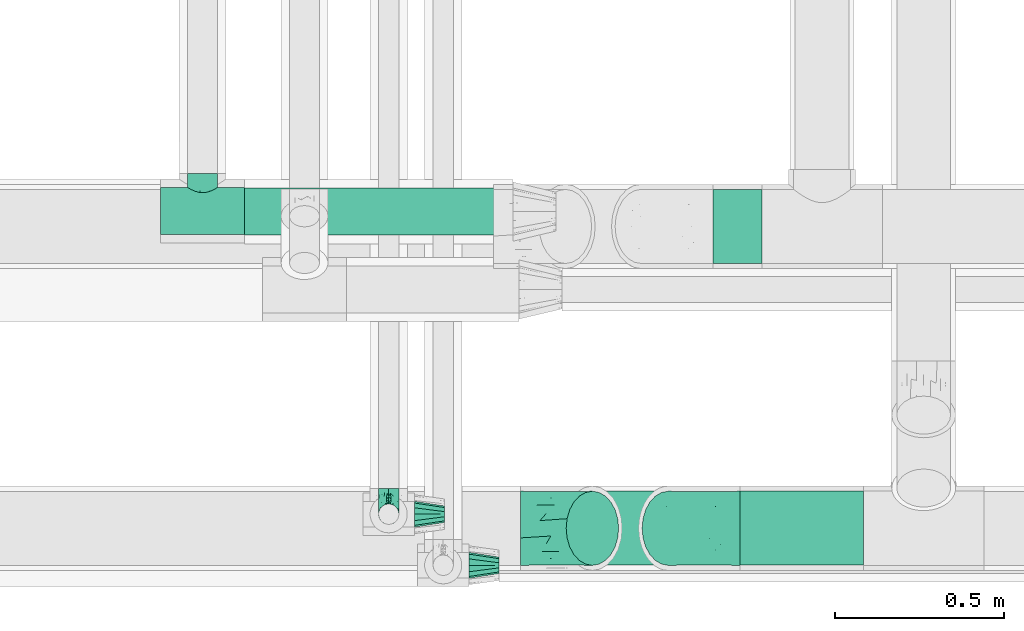
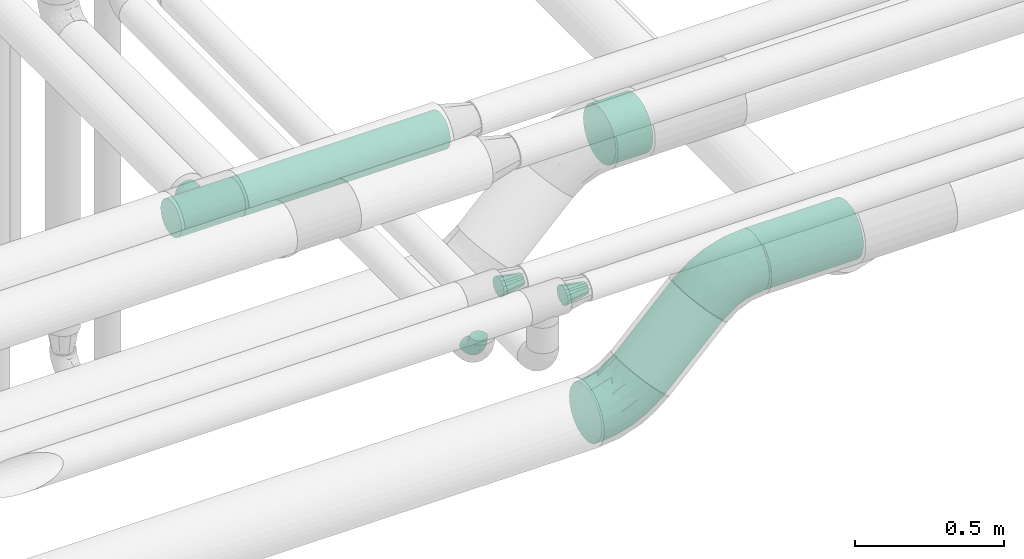
# One storey, part 604 of 827: 6 flow fittings, 4 flow segments.
"""IFC2X3 building model written with IfcOpenShell, lengths in millimetres."""

from ifc_helpers import new_model, entity, si_unit, converted_unit, derived_unit, direction, frame, origin, origin_2d_with_axis, place, context, subcontext, project, spatial, circle, extrude, faceted_brep, source, transform, mapped, material, type_object, type_shapes, element, save


model = new_model("IFC2X3")

# Units and contexts
model_context = context("Model", 3, precision=0.01, world=origin(), true_north=direction((6.12303176911189e-17, 1.0)))
body_context = subcontext(model_context, "Body", "Model", "MODEL_VIEW")
ifc_project = project(units=[si_unit("LENGTHUNIT", "METRE", prefix="MILLI"), si_unit("AREAUNIT", "SQUARE_METRE"), si_unit("VOLUMEUNIT", "CUBIC_METRE"), converted_unit("PLANEANGLEUNIT", "DEGREE", entity("IfcRatioMeasure", 0.0174532925199433), si_unit("PLANEANGLEUNIT", "RADIAN"), dimensions=[0, 0, 0, 0, 0, 0, 0]), si_unit("MASSUNIT", "GRAM", prefix="KILO"), derived_unit("MASSDENSITYUNIT", [(si_unit("MASSUNIT", "GRAM", prefix="KILO"), 1), (si_unit("LENGTHUNIT", "METRE"), -3)]), derived_unit("MOMENTOFINERTIAUNIT", [(si_unit("LENGTHUNIT", "METRE"), 4)]), si_unit("TIMEUNIT", "SECOND"), si_unit("FREQUENCYUNIT", "HERTZ"), si_unit("THERMODYNAMICTEMPERATUREUNIT", "DEGREE_CELSIUS"), derived_unit("THERMALTRANSMITTANCEUNIT", [(si_unit("MASSUNIT", "GRAM", prefix="KILO"), 1), (si_unit("THERMODYNAMICTEMPERATUREUNIT", "KELVIN"), -1), (si_unit("TIMEUNIT", "SECOND"), -3)]), derived_unit("VOLUMETRICFLOWRATEUNIT", [(si_unit("LENGTHUNIT", "METRE"), 3), (si_unit("TIMEUNIT", "SECOND"), -1)]), derived_unit("MASSFLOWRATEUNIT", [(si_unit("MASSUNIT", "GRAM", prefix="KILO"), 1), (si_unit("TIMEUNIT", "SECOND"), -1)]), derived_unit("ROTATIONALFREQUENCYUNIT", [(si_unit("TIMEUNIT", "SECOND"), -1)]), si_unit("ELECTRICCURRENTUNIT", "AMPERE"), si_unit("ELECTRICVOLTAGEUNIT", "VOLT"), si_unit("POWERUNIT", "WATT"), si_unit("FORCEUNIT", "NEWTON", prefix="KILO"), si_unit("ILLUMINANCEUNIT", "LUX"), si_unit("LUMINOUSFLUXUNIT", "LUMEN"), si_unit("LUMINOUSINTENSITYUNIT", "CANDELA"), derived_unit("USERDEFINED", [(si_unit("MASSUNIT", "GRAM", prefix="KILO"), -1), (si_unit("LENGTHUNIT", "METRE"), -2), (si_unit("TIMEUNIT", "SECOND"), 3), (si_unit("LUMINOUSFLUXUNIT", "LUMEN"), 1)]), derived_unit("LINEARVELOCITYUNIT", [(si_unit("LENGTHUNIT", "METRE"), 1), (si_unit("TIMEUNIT", "SECOND"), -1)]), si_unit("PRESSUREUNIT", "PASCAL"), derived_unit("USERDEFINED", [(si_unit("LENGTHUNIT", "METRE"), -2), (si_unit("MASSUNIT", "GRAM", prefix="KILO"), 1), (si_unit("TIMEUNIT", "SECOND"), -2)]), derived_unit("LINEARFORCEUNIT", [(si_unit("MASSUNIT", "GRAM", prefix="KILO"), 1), (si_unit("LENGTHUNIT", "METRE"), 1), (si_unit("TIMEUNIT", "SECOND"), -2), (si_unit("LENGTHUNIT", "METRE"), -1)]), derived_unit("PLANARFORCEUNIT", [(si_unit("MASSUNIT", "GRAM", prefix="KILO"), 1), (si_unit("LENGTHUNIT", "METRE"), 1), (si_unit("TIMEUNIT", "SECOND"), -2), (si_unit("LENGTHUNIT", "METRE"), -2)])], contexts=[model_context])

# Site, building, storey
site_placement = place(None, origin())
site = spatial("IfcSite", under=ifc_project, at=site_placement, CompositionType="ELEMENT")
building_placement = place(site_placement, origin())
building = spatial("IfcBuilding", under=site, at=building_placement, CompositionType="ELEMENT")
storey_placement = place(building_placement, frame((0.0, 0.0, 28200.0)))
storey = spatial("IfcBuildingStorey", under=building, at=storey_placement, Name="08", CompositionType="ELEMENT", Elevation=28200.0)

# Flow segments
pipe_segment_type_1 = type_object("IfcPipeSegmentType", PredefinedType="NOTDEFINED")
flow_segment_1_placement = place(storey_placement, frame((37506.49, 6263.9, 2788.9)))
element("IfcFlowSegment", 1, at=flow_segment_1_placement, inside=storey, type_object=pipe_segment_type_1, context=body_context, shape_type="SweptSolid", body=[
    extrude(circle(Radius=109.5, at=origin_2d_with_axis()), frame((0.0, 111.1, 111.1), z_axis=(1.0, 0.0, 0.0), x_axis=(0.0, 1.0, 0.0)), (0.0, 0.0, 1.0), 363.810001287764),
])
flow_segment_2_placement = place(storey_placement, frame((36991.07, 6263.9, 2508.84)))
element("IfcFlowSegment", 2, at=flow_segment_2_placement, inside=storey, type_object=pipe_segment_type_1, context=body_context, shape_type="SweptSolid", body=[
    extrude(circle(Radius=109.5, at=origin_2d_with_axis()), frame((79.02, 111.1, 79.02), z_axis=(0.70710679250001, 0.0, 0.707106769873085), x_axis=(0.0, 1.0, 0.0)), (0.0, 0.0, 1.0), 317.157302199655),
])
flow_segment_3_placement = place(storey_placement, frame((37426.66, 7155.11, 2788.78)))
element("IfcFlowSegment", 3, at=flow_segment_3_placement, inside=storey, type_object=pipe_segment_type_1, context=body_context, shape_type="SweptSolid", body=[
    extrude(circle(Radius=109.5, at=origin_2d_with_axis()), frame((0.0, 111.1, 111.1), z_axis=(1.0, 0.0, 0.0), x_axis=(0.0, 1.0, 0.0)), (0.0, 0.0, 1.0), 143.641200592173),
])
pipe_segment_type_2 = type_object("IfcPipeSegmentType", PredefinedType="NOTDEFINED")
flow_segment_4_placement = place(storey_placement, frame((36043.07, 7238.4, 3028.4)))
element("IfcFlowSegment", 4, at=flow_segment_4_placement, inside=storey, type_object=pipe_segment_type_2, context=body_context, shape_type="SweptSolid", body=[
    extrude(circle(Radius=70.0, at=origin_2d_with_axis()), frame((0.0, 71.6, 71.6), z_axis=(1.0, 0.0, 0.0), x_axis=(0.0, 1.0, 0.0)), (0.0, 0.0, 1.0), 791.966250687601),
])

# Flow fittings
ifc_material = material()
pipe_fitting_type_1 = type_object("IfcPipeFittingType", Name="ADSK_1", PredefinedType="NOTDEFINED", material=ifc_material)
shared_shape_1 = source(origin(), body_context, "Body", "Brep", [
    faceted_brep([(-76.0, 15.07, -26.11), (-76.0, 7.8, -29.12), (-76.0, 0.0, -30.15), (-76.0, -7.8, -29.12), (-76.0, -15.08, -26.11), (-76.0, -21.32, -21.32), (-76.0, -26.11, -15.08), (-76.0, -29.12, -7.8), (-76.0, -30.15, 0.0), (-76.0, -29.12, 7.8), (-76.0, -26.11, 15.07), (-76.0, -21.32, 21.32), (-76.0, -15.08, 26.11), (-76.0, -7.8, 29.12), (-76.0, 0.0, 30.15), (-76.0, 7.8, 29.12), (-76.0, 15.07, 26.11), (-76.0, 21.32, 21.32), (-76.0, 26.11, 15.07), (-76.0, 29.12, 7.8), (-76.0, 30.15, 0.0), (-76.0, 29.12, -7.8), (-76.0, 26.11, -15.08), (-76.0, 21.32, -21.32), (0.0, 76.0, -30.15), (-7.8, 76.0, -29.12), (-15.07, 76.0, -26.11), (-21.32, 76.0, -21.32), (-26.11, 76.0, -15.08), (-29.12, 76.0, -7.8), (-30.15, 76.0, 0.0), (-29.12, 76.0, 7.8), (-26.11, 76.0, 15.07), (-21.32, 76.0, 21.32), (-15.07, 76.0, 26.11), (-7.8, 76.0, 29.12), (0.0, 76.0, 30.15), (7.8, 76.0, 29.12), (15.08, 76.0, 26.11), (21.32, 76.0, 21.32), (26.11, 76.0, 15.07), (29.12, 76.0, 7.8), (30.15, 76.0, 0.0), (29.12, 76.0, -7.8), (26.11, 76.0, -15.08), (21.32, 76.0, -21.32), (15.08, 76.0, -26.11), (7.8, 76.0, -29.12), (10.79, 31.43, 21.07), (4.32, 31.7, 25.72), (1.65, 15.19, 19.92), (-61.17, -27.8, 0.0), (-51.1, -25.49, 9.84), (-56.14, -10.61, 27.27), (-31.7, -4.32, 25.72), (-39.75, 1.72, 29.41), (-43.2, -24.95, 0.0), (-1.86, 1.86, 0.0), (4.49, 7.65, 5.78), (-7.82, -4.61, 5.83), (-56.21, -22.79, 17.21), (-58.98, -3.38, 29.7), (-53.96, 5.6, 30.07), (-10.86, 10.86, 25.48), (-17.2, -2.6, 20.44), (-49.15, -16.01, 22.7), (-22.18, -14.24, 7.99), (-28.4, -17.42, 0.0), (-13.61, -9.88, 0.0), (-39.0, 23.48, 27.76), (-58.76, 12.54, 28.36), (-41.61, 15.41, 29.48), (16.01, 49.15, 22.7), (-58.55, 25.93, 19.53), (-51.53, 33.5, 13.51), (-64.92, 28.76, 12.4), (-7.48, 23.14, 28.25), (-1.72, 39.75, 29.41), (-12.04, 27.88, 29.88), (-63.91, 18.81, 24.52), (-11.63, 65.16, 28.18), (-4.97, 57.02, 30.05), (9.88, 13.61, 0.0), (-62.5, 31.74, 5.02), (-45.17, 30.98, 21.2), (-21.78, 9.76, 28.58), (10.61, 56.14, 27.27), (-32.09, 54.42, 13.26), (22.79, 56.21, 17.21), (15.38, 31.17, 15.63), (25.49, 51.1, 9.84), (21.84, 36.35, 5.92), (24.95, 43.2, 0.0), (3.38, 58.98, 29.7), (-31.17, -15.38, 15.63), (-39.39, 41.78, 15.45), (-34.56, 41.13, 20.79), (-39.81, -23.25, 5.49), (27.8, 61.17, 0.0), (-31.74, 62.5, 5.02), (-53.07, 36.29, 0.0), (-42.95, 42.95, 7.29), (-36.29, 53.07, 0.0), (-19.83, 58.51, 24.79), (-25.48, 60.2, 19.41), (-14.53, 50.96, 28.57), (-13.31, 37.09, 30.07), (-26.16, 40.06, 26.4), (-32.43, -10.35, 21.9), (17.42, 28.4, 0.0), (14.24, 22.18, 7.99), (-38.67, 9.72, 30.15), (-24.66, 17.36, 30.09), (-37.08, 31.49, 24.99), (-49.27, 22.83, 25.24), (-20.8, 38.81, 28.63), (-27.58, 27.58, 29.2), (-36.07, -20.23, 10.71), (-15.19, -6.16, 14.9), (6.6, 15.4, 14.49), (-2.51, 2.51, 11.35), (-65.16, 11.63, -28.18), (-49.15, -16.01, -22.7), (-57.02, 4.97, -30.05), (-25.93, 58.55, -19.53), (-33.5, 51.53, -13.51), (-28.76, 64.92, -12.4), (-60.2, 25.48, -19.41), (-58.51, 19.83, -24.79), (4.61, 7.82, -5.83), (-7.65, -4.49, -5.78), (-2.51, 2.51, -11.35), (-62.5, 31.74, -5.02), (-50.96, 14.53, -28.57), (-37.09, 13.31, -30.07), (-42.95, 42.95, -7.29), (25.49, 51.1, -9.84), (22.79, 56.21, -17.21), (-40.06, 26.16, -26.4), (3.38, 58.98, -29.7), (-5.6, 53.96, -30.07), (-27.88, 12.04, -29.88), (-9.76, 21.78, -28.58), (-23.14, 7.48, -28.25), (-51.1, -25.49, -9.84), (15.38, 31.17, -15.63), (16.01, 49.15, -22.7), (-23.48, 39.0, -27.76), (-12.54, 58.76, -28.36), (-15.41, 41.61, -29.48), (-56.21, -22.79, -17.21), (-9.72, 38.67, -30.15), (-17.36, 24.66, -30.09), (-22.18, -14.24, -7.99), (-41.13, 34.56, -20.79), (-31.74, 62.5, -5.02), (-58.98, -3.38, -29.7), (-31.17, -15.38, -15.63), (-56.14, -10.61, -27.27), (14.24, 22.18, -7.99), (23.25, 39.81, -5.49), (-31.49, 37.08, -24.99), (-15.19, -6.16, -14.9), (1.65, 15.19, -19.92), (-18.81, 63.91, -24.52), (-32.59, -11.62, -20.84), (-31.7, -4.32, -25.72), (-17.2, -2.6, -20.44), (-39.75, 1.72, -29.41), (-54.42, 32.09, -13.26), (-30.98, 45.17, -21.2), (10.61, 56.14, -27.27), (10.23, 31.31, -21.52), (4.32, 31.7, -25.72), (-41.78, 39.39, -15.45), (-1.72, 39.75, -29.41), (-36.35, -21.84, -5.92), (-22.83, 49.27, -25.24), (-38.81, 20.8, -28.63), (-27.58, 27.58, -29.2), (-10.86, 10.86, -25.48), (20.23, 36.07, -10.71), (6.6, 15.4, -14.49)], [[[0, 1, 2, 3, 4, 5, 6, 7, 8, 9, 10, 11, 12, 13, 14, 15, 16, 17, 18, 19, 20, 21, 22, 23]], [[24, 25, 26, 27, 28, 29, 30, 31, 32, 33, 34, 35, 36, 37, 38, 39, 40, 41, 42, 43, 44, 45, 46, 47]], [[48, 49, 50]], [[51, 52, 9]], [[53, 54, 55]], [[9, 52, 10]], [[56, 52, 51]], [[57, 58, 59]], [[11, 10, 60]], [[14, 61, 62]], [[63, 54, 64]], [[65, 12, 11]], [[65, 53, 12]], [[66, 67, 68]], [[69, 70, 71]], [[72, 39, 38]], [[73, 74, 75]], [[15, 70, 16]], [[76, 77, 78]], [[16, 79, 17]], [[13, 61, 14]], [[35, 80, 81]], [[14, 62, 15]], [[17, 73, 18]], [[57, 82, 58]], [[20, 19, 83]], [[75, 19, 18]], [[70, 15, 62]], [[73, 84, 74]], [[78, 85, 76]], [[38, 86, 72]], [[32, 31, 87]], [[88, 89, 90]], [[91, 92, 90]], [[72, 86, 49]], [[36, 93, 37]], [[75, 83, 19]], [[36, 35, 81]], [[60, 94, 65]], [[40, 90, 41]], [[95, 96, 87]], [[88, 90, 40]], [[66, 97, 67]], [[90, 98, 41]], [[40, 39, 88]], [[99, 31, 30]], [[20, 83, 100]], [[101, 102, 100]], [[52, 60, 10]], [[102, 99, 30]], [[96, 103, 104]], [[83, 101, 100]], [[12, 53, 13]], [[104, 103, 33]], [[105, 106, 81]], [[107, 105, 103]], [[64, 54, 108]], [[80, 103, 105]], [[80, 35, 34]], [[34, 33, 103]], [[86, 38, 37]], [[109, 110, 82]], [[71, 111, 112]], [[69, 107, 113]], [[79, 73, 17]], [[114, 113, 84]], [[33, 32, 104]], [[115, 107, 116]], [[105, 115, 106]], [[93, 81, 77]], [[54, 53, 65]], [[61, 53, 55]], [[108, 94, 64]], [[54, 63, 85]], [[93, 86, 37]], [[77, 76, 49]], [[77, 49, 86]], [[49, 63, 50]], [[60, 52, 117]], [[65, 11, 60]], [[39, 72, 88]], [[89, 88, 72]], [[71, 70, 62]], [[79, 70, 114]], [[103, 96, 107]], [[69, 113, 114]], [[112, 106, 116]], [[77, 81, 106]], [[112, 116, 71]], [[112, 55, 85]], [[64, 50, 63]], [[57, 59, 68]], [[32, 87, 104]], [[96, 104, 87]], [[94, 118, 64]], [[50, 119, 89]], [[50, 64, 118]], [[50, 89, 48]], [[81, 93, 36]], [[86, 93, 77]], [[53, 61, 13]], [[62, 61, 55]], [[71, 62, 111]], [[69, 71, 116]], [[95, 101, 74]], [[99, 101, 87]], [[118, 66, 59]], [[117, 97, 66]], [[117, 66, 94]], [[91, 89, 110]], [[91, 110, 109]], [[110, 89, 119]], [[9, 8, 51]], [[98, 90, 92]], [[98, 42, 41]], [[101, 83, 74]], [[101, 99, 102]], [[87, 31, 99]], [[62, 55, 111]], [[55, 112, 111]], [[107, 69, 116]], [[70, 69, 114]], [[107, 96, 113]], [[84, 113, 96]], [[84, 96, 95]], [[114, 84, 73]], [[70, 79, 16]], [[73, 79, 114]], [[54, 85, 55]], [[76, 85, 63]], [[49, 76, 63]], [[77, 106, 78]], [[106, 112, 78]], [[85, 78, 112]], [[73, 75, 18]], [[83, 75, 74]], [[103, 80, 34]], [[81, 80, 105]], [[101, 95, 87]], [[84, 95, 74]], [[106, 115, 116]], [[105, 107, 115]], [[120, 59, 58]], [[82, 110, 58]], [[119, 58, 110]], [[118, 59, 120]], [[66, 68, 59]], [[54, 65, 108]], [[94, 108, 65]], [[66, 118, 94]], [[50, 118, 120]], [[50, 120, 119]], [[119, 120, 58]], [[89, 72, 48]], [[49, 48, 72]], [[60, 117, 94]], [[117, 52, 97]], [[52, 56, 97]], [[67, 97, 56]], [[92, 91, 109]], [[89, 91, 90]], [[121, 1, 0]], [[122, 5, 4]], [[2, 1, 123]], [[124, 125, 126]], [[127, 128, 23]], [[129, 130, 131]], [[100, 132, 20]], [[133, 134, 123]], [[135, 100, 102]], [[136, 137, 44]], [[133, 128, 138]], [[24, 139, 140]], [[141, 142, 143]], [[121, 128, 133]], [[6, 144, 7]], [[137, 145, 146]], [[144, 51, 7]], [[147, 148, 149]], [[144, 6, 150]], [[149, 151, 152]], [[153, 68, 67]], [[154, 128, 127]], [[30, 155, 102]], [[43, 42, 98]], [[156, 3, 2]], [[157, 144, 150]], [[158, 4, 3]], [[24, 140, 25]], [[155, 135, 102]], [[159, 160, 109]], [[30, 29, 155]], [[147, 138, 161]], [[27, 124, 28]], [[57, 129, 82]], [[162, 163, 131]], [[27, 26, 164]], [[148, 26, 25]], [[165, 166, 167]], [[24, 47, 139]], [[143, 168, 141]], [[22, 21, 169]], [[125, 124, 170]], [[148, 25, 140]], [[46, 146, 171]], [[158, 122, 4]], [[0, 23, 128]], [[1, 121, 123]], [[109, 82, 159]], [[45, 44, 137]], [[146, 46, 45]], [[136, 43, 98]], [[132, 21, 20]], [[136, 98, 92]], [[172, 173, 146]], [[46, 171, 47]], [[43, 136, 44]], [[174, 154, 169]], [[171, 173, 175]], [[6, 5, 150]], [[126, 29, 28]], [[176, 56, 144]], [[122, 158, 166]], [[164, 124, 27]], [[177, 161, 170]], [[23, 22, 127]], [[178, 138, 179]], [[133, 178, 134]], [[156, 123, 168]], [[156, 158, 3]], [[168, 143, 166]], [[168, 166, 158]], [[166, 180, 167]], [[173, 171, 146]], [[139, 171, 175]], [[172, 145, 163]], [[173, 180, 142]], [[5, 122, 150]], [[157, 150, 122]], [[137, 136, 181]], [[146, 45, 137]], [[149, 148, 140]], [[164, 148, 177]], [[128, 154, 138]], [[147, 161, 177]], [[152, 134, 179]], [[168, 123, 134]], [[152, 179, 149]], [[152, 175, 142]], [[57, 130, 129]], [[157, 165, 167]], [[22, 169, 127]], [[154, 127, 169]], [[163, 167, 180]], [[162, 157, 167]], [[173, 163, 180]], [[182, 163, 145]], [[123, 156, 2]], [[158, 156, 168]], [[171, 139, 47]], [[140, 139, 175]], [[149, 140, 151]], [[147, 149, 179]], [[174, 135, 125]], [[132, 135, 169]], [[176, 157, 153]], [[176, 153, 67]], [[153, 157, 162]], [[182, 159, 129]], [[181, 160, 159]], [[181, 159, 145]], [[51, 144, 56]], [[51, 8, 7]], [[135, 132, 100]], [[169, 21, 132]], [[126, 155, 29]], [[135, 155, 125]], [[140, 175, 151]], [[175, 152, 151]], [[138, 147, 179]], [[148, 147, 177]], [[138, 154, 161]], [[170, 161, 154]], [[170, 154, 174]], [[177, 170, 124]], [[148, 164, 26]], [[124, 164, 177]], [[173, 142, 175]], [[143, 142, 180]], [[166, 143, 180]], [[168, 134, 141]], [[134, 152, 141]], [[142, 141, 152]], [[124, 126, 28]], [[155, 126, 125]], [[128, 121, 0]], [[123, 121, 133]], [[135, 174, 169]], [[170, 174, 125]], [[134, 178, 179]], [[133, 138, 178]], [[130, 153, 162]], [[68, 153, 130]], [[57, 68, 130]], [[182, 129, 131]], [[159, 82, 129]], [[157, 122, 165]], [[166, 165, 122]], [[163, 162, 167]], [[162, 131, 130]], [[145, 172, 146]], [[163, 173, 172]], [[159, 182, 145]], [[131, 163, 182]], [[56, 176, 67]], [[157, 176, 144]], [[137, 181, 145]], [[181, 136, 160]], [[136, 92, 160]], [[109, 160, 92]]]),
])
type_shapes(pipe_fitting_type_1, [shared_shape_1])
flow_fitting_1_placement = place(storey_placement, frame((36468.72, 6416.57, 2850.0), z_axis=(-1.0, 0.0, 0.0), x_axis=(0.0, -1.0, 0.0)))
element("IfcFlowFitting", 5, at=flow_fitting_1_placement, inside=storey, type_object=pipe_fitting_type_1, material=ifc_material, Name="ADSK_1", ObjectType="ADSK_1", context=body_context, shape_type="MappedRepresentation", body=[
    mapped(shared_shape_1, transform((0.0, 0.0, 0.0), scale=1.0)),
])
pipe_fitting_type_2 = type_object("IfcPipeFittingType", Name="ADSK_1", PredefinedType="NOTDEFINED", material=ifc_material)
shared_shape_2 = source(origin(), body_context, "Body", "Brep", [
    faceted_brep([(-124.0, 18.08, -67.47), (-124.0, 0.0, -69.85), (-124.0, -18.08, -67.47), (-124.0, -34.93, -60.49), (-124.0, -49.39, -49.39), (-124.0, -60.49, -34.93), (-124.0, -63.98, -26.5), (-124.0, -67.47, -18.08), (-124.0, -69.85, 0.0), (-124.0, -67.47, 18.08), (-124.0, -63.98, 26.5), (-124.0, -60.49, 34.92), (-124.0, -49.39, 49.39), (-124.0, -34.93, 60.49), (-124.0, -18.08, 67.47), (-124.0, 0.0, 69.85), (-124.0, 18.08, 67.47), (-124.0, 34.92, 60.49), (-124.0, 49.39, 49.39), (-124.0, 60.49, 34.92), (-124.0, 67.47, 18.08), (-124.0, 69.85, 0.0), (-124.0, 67.47, -18.08), (-124.0, 60.49, -34.93), (-124.0, 49.39, -49.39), (-124.0, 34.92, -60.49), (124.0, 49.39, -49.39), (124.0, 60.49, -34.93), (124.0, 67.47, -18.08), (124.0, 69.85, 0.0), (124.0, 67.47, 18.08), (124.0, 60.49, 34.92), (124.0, 49.39, 49.39), (124.0, 34.92, 60.49), (124.0, 18.08, 67.47), (124.0, 0.0, 69.85), (124.0, -18.08, 67.47), (124.0, -34.93, 60.49), (124.0, -49.39, 49.39), (124.0, -60.49, 34.92), (124.0, -63.98, 26.5), (124.0, -67.47, 18.08), (124.0, -69.85, 0.0), (124.0, -67.47, -18.08), (124.0, -63.98, -26.5), (124.0, -60.49, -34.93), (124.0, -49.39, -49.39), (124.0, -34.93, -60.49), (124.0, -18.08, -67.47), (124.0, 0.0, -69.85), (124.0, 18.08, -67.47), (124.0, 34.92, -60.49), (41.64, -68.1, 15.55), (43.05, -68.97, 7.77), (44.45, -69.85, 0.0), (33.91, -63.66, 28.74), (22.41, -58.36, 38.39), (7.93, -54.46, 43.74), (15.17, -56.41, 41.06), (-33.91, -63.66, 28.74), (-44.45, -69.85, 0.0), (-43.05, -68.97, 7.77), (-41.64, -68.1, 15.55), (-22.41, -58.36, 38.39), (-7.93, -54.46, 43.74), (0.0, -54.46, 43.74), (22.41, -58.36, -38.39), (-33.91, -63.66, -28.74), (15.17, -56.41, -41.06), (7.93, -54.46, -43.74), (33.91, -63.66, -28.74), (41.64, -68.1, -15.55), (43.05, -68.97, -7.77), (-7.93, -54.46, -43.74), (-22.41, -58.36, -38.39), (0.0, -54.46, -43.74), (-41.64, -68.1, -15.55), (-43.05, -68.97, -7.77), (31.43, -111.0, -31.43), (38.49, -111.0, -22.23), (42.94, -111.0, -11.5), (44.45, -111.0, 0.0), (42.94, -111.0, 11.5), (38.49, -111.0, 22.22), (31.43, -111.0, 31.43), (22.23, -111.0, 38.49), (11.5, -111.0, 42.94), (0.0, -111.0, 44.45), (-11.5, -111.0, 42.94), (-22.22, -111.0, 38.49), (-31.43, -111.0, 31.43), (-38.49, -111.0, 22.22), (-42.94, -111.0, 11.5), (-44.45, -111.0, 0.0), (-42.94, -111.0, -11.5), (-38.49, -111.0, -22.23), (-31.43, -111.0, -31.43), (-22.22, -111.0, -38.49), (-11.5, -111.0, -42.94), (0.0, -111.0, -44.45), (11.5, -111.0, -42.94), (22.23, -111.0, -38.49)], [[[0, 1, 2, 3, 4, 5, 6, 7, 8, 9, 10, 11, 12, 13, 14, 15, 16, 17, 18, 19, 20, 21, 22, 23, 24, 25]], [[26, 27, 28, 29, 30, 31, 32, 33, 34, 35, 36, 37, 38, 39, 40, 41, 42, 43, 44, 45, 46, 47, 48, 49, 50, 51]], [[42, 41, 52]], [[42, 52, 53, 54]], [[41, 55, 52]], [[39, 38, 56]], [[56, 55, 39]], [[38, 57, 58, 56]], [[38, 12, 57]], [[39, 55, 41, 40]], [[59, 11, 10, 9]], [[8, 60, 61, 62]], [[9, 8, 62]], [[62, 59, 9]], [[63, 64, 12]], [[63, 11, 59]], [[11, 63, 12]], [[12, 64, 65, 57]], [[38, 37, 13, 12]], [[15, 14, 36, 35]], [[14, 13, 37, 36]], [[16, 15, 35, 34]], [[31, 30, 20, 19]], [[18, 17, 33, 32]], [[19, 18, 32, 31]], [[34, 33, 17, 16]], [[21, 20, 30, 29]], [[22, 28, 27, 23]], [[27, 26, 24, 23]], [[29, 28, 22, 21]], [[49, 48, 2, 1]], [[0, 25, 51, 50]], [[1, 0, 50, 49]], [[26, 51, 25, 24]], [[47, 3, 2, 48]], [[47, 46, 4, 3]], [[46, 45, 66]], [[67, 7, 6, 5]], [[46, 66, 68, 69]], [[45, 70, 66]], [[46, 69, 4]], [[43, 42, 71]], [[71, 70, 43]], [[42, 54, 72, 71]], [[43, 70, 45, 44]], [[73, 74, 4]], [[5, 4, 74]], [[74, 67, 5]], [[4, 69, 75, 73]], [[67, 76, 7]], [[76, 8, 7]], [[8, 76, 77, 60]], [[78, 79, 80, 81, 82, 83, 84, 85, 86, 87, 88, 89, 90, 91, 92, 93, 94, 95, 96, 97, 98, 99, 100, 101]], [[87, 64, 88]], [[63, 90, 89]], [[90, 59, 91]], [[63, 89, 88]], [[61, 60, 93]], [[93, 92, 61]], [[92, 91, 62]], [[92, 62, 61]], [[59, 62, 91]], [[90, 63, 59]], [[53, 81, 54]], [[88, 64, 63]], [[87, 57, 65, 64]], [[85, 56, 58]], [[84, 56, 85]], [[52, 83, 82]], [[84, 83, 55]], [[57, 87, 86]], [[58, 57, 86]], [[85, 58, 86]], [[56, 84, 55]], [[55, 83, 52]], [[53, 52, 82]], [[81, 53, 82]], [[80, 72, 81]], [[68, 101, 100]], [[68, 66, 101]], [[80, 71, 72]], [[80, 79, 71]], [[77, 76, 94]], [[78, 70, 79]], [[72, 54, 81]], [[71, 79, 70]], [[99, 69, 100]], [[66, 70, 78]], [[100, 69, 68]], [[66, 78, 101]], [[99, 73, 75, 69]], [[74, 98, 97]], [[96, 74, 97]], [[76, 95, 94]], [[96, 95, 67]], [[73, 99, 98]], [[98, 74, 73]], [[74, 96, 67]], [[67, 95, 76]], [[93, 77, 94]], [[77, 93, 60]]]),
])
type_shapes(pipe_fitting_type_2, [shared_shape_2])
flow_fitting_2_placement = place(storey_placement, frame((35919.07, 7311.73, 3100.0), z_axis=(0.0, 0.0, -1.0), x_axis=(1.0, 0.0, 0.0)))
element("IfcFlowFitting", 6, at=flow_fitting_2_placement, inside=storey, type_object=pipe_fitting_type_2, material=ifc_material, Name="ADSK_1", ObjectType="ADSK_1", context=body_context, shape_type="MappedRepresentation", body=[
    mapped(shared_shape_2, transform((0.0, 0.0, 0.0), scale=1.0)),
])
pipe_fitting_type_3 = type_object("IfcPipeFittingType", Name="ADSK_2", PredefinedType="NOTDEFINED", material=ifc_material)
shared_shape_3 = source(origin(), body_context, "Body", "Brep", [
    faceted_brep([(-124.26, 54.75, -94.83), (-124.26, 28.34, -105.77), (-124.26, 0.0, -109.5), (-124.26, -28.34, -105.77), (-124.26, -54.75, -94.83), (-124.26, -77.43, -77.43), (-124.26, -94.83, -54.75), (-124.26, -105.77, -28.34), (-124.26, -109.5, 0.0), (-124.26, -105.77, 28.34), (-124.26, -94.83, 54.75), (-124.26, -77.43, 77.43), (-124.26, -54.75, 94.83), (-124.26, -28.34, 105.77), (-124.26, 0.0, 109.5), (-124.26, 28.34, 105.77), (-124.26, 54.75, 94.83), (-124.26, 77.43, 77.43), (-124.26, 94.83, 54.75), (-124.26, 105.77, 28.34), (-124.26, 109.5, 0.0), (-124.26, 105.77, -28.34), (-124.26, 94.83, -54.75), (-124.26, 77.43, -77.43), (87.87, 87.87, -109.5), (67.83, 107.91, -105.77), (49.15, 126.58, -94.83), (33.12, 142.62, -77.43), (20.81, 154.92, -54.75), (13.08, 162.66, -28.34), (10.44, 165.3, 0.0), (13.08, 162.66, 28.34), (20.81, 154.92, 54.75), (33.12, 142.62, 77.43), (49.15, 126.58, 94.83), (67.83, 107.91, 105.77), (87.87, 87.87, 109.5), (107.91, 67.83, 105.77), (126.58, 49.15, 94.83), (142.62, 33.12, 77.43), (154.92, 20.81, 54.75), (162.66, 13.08, 28.34), (165.3, 10.44, 0.0), (162.66, 13.08, -28.34), (154.92, 20.81, -54.75), (142.62, 33.12, -77.43), (126.58, 49.15, -94.83), (107.91, 67.83, -105.77), (71.66, 17.62, 100.41), (2.28, -89.46, 0.0), (-32.68, -94.9, 29.76), (-60.2, -104.46, 0.0), (40.7, 64.7, 108.77), (-50.51, -81.19, 64.81), (-37.02, -58.34, 85.18), (-45.56, -6.91, 108.2), (14.88, -35.92, 89.14), (-63.13, -38.21, 100.41), (-13.48, 32.55, 108.99), (10.95, 77.81, 101.97), (-55.11, 49.0, 102.07), (-33.95, 81.95, 88.86), (-74.53, 16.96, 108.77), (31.61, -76.31, 21.78), (90.21, -44.0, 29.76), (-61.62, 94.79, 68.49), (-47.74, 115.26, 44.52), (27.74, -66.97, 50.42), (-65.18, -94.31, 47.39), (-34.75, 129.14, 22.76), (-87.1, 113.16, 0.0), (61.65, -64.87, 0.0), (116.43, -31.29, 0.0), (67.43, -15.08, 85.18), (80.19, -41.7, 48.45), (93.12, -21.69, 64.81), (37.11, 27.33, 108.2), (15.28, -56.47, 71.64), (-8.95, 119.52, 68.0), (-18.43, 141.61, 0.0), (-51.36, 124.0, 0.0), (8.08, -19.5, 99.45), (-74.53, 16.96, -108.77), (-45.56, -6.91, -108.2), (90.21, -44.0, -29.76), (-33.95, 81.95, -88.86), (4.32, 73.61, -102.07), (-66.74, 115.88, -22.76), (71.66, 17.62, -100.41), (37.11, 27.33, -108.2), (-47.74, 115.26, -44.52), (-50.51, -81.19, -64.81), (-37.02, -58.34, -85.18), (-78.18, 90.84, -68.0), (-62.76, 47.28, -101.97), (-27.22, -86.19, -48.45), (-63.13, -38.21, -100.41), (-32.68, -94.9, -29.76), (-13.48, 32.55, -108.99), (8.08, -19.5, -99.45), (14.88, -35.92, -89.14), (27.74, -66.97, -50.42), (31.61, -76.31, -21.78), (29.12, -50.74, -71.64), (93.12, -21.69, -64.81), (112.78, -20.6, -47.39), (-23.45, 110.6, -68.49), (67.43, -15.08, -85.18), (40.7, 64.7, -108.77)], [[[0, 1, 2, 3, 4, 5, 6, 7, 8, 9, 10, 11, 12, 13, 14, 15, 16, 17, 18, 19, 20, 21, 22, 23]], [[24, 25, 26, 27, 28, 29, 30, 31, 32, 33, 34, 35, 36, 37, 38, 39, 40, 41, 42, 43, 44, 45, 46, 47]], [[38, 37, 48]], [[49, 50, 51]], [[36, 35, 52]], [[11, 53, 54]], [[51, 9, 8]], [[14, 13, 55]], [[56, 57, 54]], [[58, 59, 60]], [[34, 33, 61]], [[13, 12, 57]], [[55, 58, 62]], [[49, 63, 50]], [[54, 57, 12]], [[16, 15, 60]], [[40, 64, 41]], [[61, 16, 60]], [[9, 51, 50]], [[18, 65, 66]], [[15, 14, 62]], [[67, 53, 68]], [[32, 31, 66]], [[19, 69, 70]], [[12, 11, 54]], [[70, 20, 19]], [[19, 18, 66]], [[53, 11, 10]], [[61, 17, 16]], [[18, 17, 65]], [[64, 63, 71]], [[72, 41, 64]], [[38, 73, 39]], [[74, 75, 67]], [[58, 52, 59]], [[52, 76, 36]], [[63, 67, 50]], [[76, 37, 36]], [[77, 53, 67]], [[40, 75, 74]], [[78, 61, 33]], [[38, 48, 73]], [[68, 53, 10]], [[72, 42, 41]], [[77, 75, 73]], [[17, 61, 65]], [[69, 30, 79]], [[79, 80, 69]], [[68, 9, 50]], [[75, 39, 73]], [[57, 56, 81]], [[66, 69, 19]], [[81, 76, 55]], [[66, 65, 78]], [[66, 31, 69]], [[78, 33, 32]], [[81, 48, 76]], [[57, 55, 13]], [[58, 55, 76]], [[34, 59, 35]], [[59, 61, 60]], [[77, 54, 53]], [[62, 60, 15]], [[72, 64, 71]], [[61, 59, 34]], [[40, 39, 75]], [[55, 57, 81]], [[76, 48, 37]], [[48, 81, 56]], [[75, 77, 67]], [[56, 77, 73]], [[66, 78, 32]], [[61, 78, 65]], [[55, 62, 14]], [[60, 62, 58]], [[59, 52, 35]], [[76, 52, 58]], [[71, 63, 49]], [[67, 63, 64]], [[69, 31, 30]], [[69, 80, 70]], [[77, 56, 54]], [[48, 56, 73]], [[9, 68, 10]], [[67, 68, 50]], [[67, 64, 74]], [[40, 74, 64]], [[1, 82, 2]], [[82, 83, 2]], [[83, 3, 2]], [[43, 72, 84]], [[23, 85, 0]], [[26, 25, 86]], [[70, 87, 20]], [[88, 89, 47]], [[90, 22, 21]], [[91, 5, 92]], [[93, 23, 22]], [[85, 86, 94]], [[6, 5, 91]], [[94, 1, 0]], [[6, 91, 95]], [[85, 94, 0]], [[51, 8, 7]], [[83, 96, 3]], [[49, 51, 97]], [[98, 94, 86]], [[4, 92, 5]], [[99, 96, 83]], [[88, 100, 99]], [[101, 84, 102]], [[96, 4, 3]], [[92, 4, 96]], [[95, 91, 101]], [[90, 21, 87]], [[70, 80, 87]], [[103, 91, 92]], [[101, 104, 105]], [[104, 45, 44]], [[29, 87, 79]], [[29, 79, 30]], [[106, 93, 90]], [[28, 90, 29]], [[27, 26, 85]], [[105, 43, 84]], [[86, 85, 26]], [[6, 97, 7]], [[46, 45, 107]], [[106, 90, 28]], [[28, 27, 106]], [[108, 25, 24]], [[88, 47, 46]], [[103, 107, 104]], [[51, 7, 97]], [[71, 49, 102]], [[107, 100, 88]], [[98, 108, 89]], [[97, 102, 49]], [[27, 85, 106]], [[42, 72, 43]], [[108, 86, 25]], [[99, 83, 89]], [[72, 71, 84]], [[98, 82, 94]], [[45, 104, 107]], [[93, 85, 23]], [[24, 47, 89]], [[105, 104, 44]], [[29, 90, 87]], [[103, 104, 101]], [[98, 89, 83]], [[96, 99, 100]], [[107, 88, 46]], [[89, 88, 99]], [[91, 103, 101]], [[100, 103, 92]], [[90, 93, 22]], [[85, 93, 106]], [[94, 82, 1]], [[83, 82, 98]], [[89, 108, 24]], [[86, 108, 98]], [[101, 102, 97]], [[71, 102, 84]], [[87, 21, 20]], [[87, 80, 79]], [[103, 100, 107]], [[96, 100, 92]], [[43, 105, 44]], [[101, 105, 84]], [[101, 97, 95]], [[6, 95, 97]]]),
])
type_shapes(pipe_fitting_type_3, [shared_shape_3])
for number, where, z_axis, x_axis, name in (
    (7, (37382.22, 6375.0, 2900.0), (0.0, -1.0, 0.0), (-1.0, 0.0, 0.0), "ADSK_2"),
    (8, (36982.22, 6375.0, 2500.0), (0.0, 1.0, 0.0), (-0.707106792500003, 0.0, -0.707106769873092), "ADSK_2"),
):
    element("IfcFlowFitting", number, at=place(storey_placement, frame(where, z_axis=z_axis, x_axis=x_axis)), inside=storey, type_object=pipe_fitting_type_3, material=ifc_material, Name=name, ObjectType="ADSK_2", context=body_context, shape_type="MappedRepresentation", body=[
        mapped(shared_shape_3, transform((0.0, 0.0, 0.0), scale=1.0)),
    ])
pipe_fitting_type_4 = type_object("IfcPipeFittingType", Name="ADSK_1", PredefinedType="NOTDEFINED", material=ifc_material)
shared_shape_4 = source(origin(), body_context, "Body", "Brep", [
    faceted_brep([(89.0, -19.54, 14.2), (89.0, -21.84, 7.1), (89.0, -24.15, 0.0), (89.0, -21.84, -7.1), (89.0, -19.54, -14.2), (89.0, -13.5, -18.58), (89.0, -7.46, -22.97), (89.0, 0.0, -22.97), (89.0, 7.46, -22.97), (89.0, 13.5, -18.58), (89.0, 19.54, -14.2), (89.0, 21.84, -7.1), (89.0, 24.15, 0.0), (89.0, 21.84, 7.1), (89.0, 19.54, 14.2), (89.0, 13.5, 18.58), (89.0, 7.46, 22.97), (89.0, 0.0, 22.97), (89.0, -7.46, 22.97), (89.0, -13.5, 18.58), (0.0, 0.0, 38.05), (0.0, 9.51, 35.5), (0.0, 19.02, 32.95), (0.0, 25.99, 25.99), (0.0, 32.95, 19.02), (0.0, 36.21, 6.85), (0.0, 38.05, 0.0), (0.0, 36.21, -6.85), (0.0, 32.95, -19.02), (0.0, 25.99, -25.99), (0.0, 19.03, -32.95), (0.0, 9.51, -35.5), (0.0, 0.0, -38.05), (0.0, -9.51, -35.5), (0.0, -19.03, -32.95), (0.0, -25.99, -25.99), (0.0, -32.95, -19.03), (0.0, -36.21, -6.85), (0.0, -38.05, 0.0), (0.0, -36.21, 6.85), (0.0, -32.95, 19.02), (0.0, -25.99, 25.99), (0.0, -19.02, 32.95), (0.0, -9.51, 35.5)], [[[0, 1, 2, 3, 4, 5, 6, 7, 8, 9, 10, 11, 12, 13, 14, 15, 16, 17, 18, 19]], [[20, 21, 22, 23, 24, 25, 26, 27, 28, 29, 30, 31, 32, 33, 34, 35, 36, 37, 38, 39, 40, 41, 42, 43]], [[34, 5, 35]], [[35, 4, 36]], [[4, 35, 5]], [[4, 3, 36]], [[3, 2, 37]], [[9, 8, 30]], [[34, 6, 5]], [[6, 34, 33]], [[7, 31, 8]], [[33, 7, 6]], [[9, 29, 10]], [[27, 26, 12]], [[7, 32, 31]], [[11, 27, 12]], [[3, 37, 36]], [[31, 30, 8]], [[38, 37, 2]], [[10, 28, 11]], [[29, 28, 10]], [[27, 11, 28]], [[29, 9, 30]], [[32, 7, 33]], [[22, 15, 23]], [[23, 14, 24]], [[14, 23, 15]], [[14, 13, 24]], [[13, 12, 25]], [[19, 18, 42]], [[22, 16, 15]], [[16, 22, 21]], [[17, 43, 18]], [[21, 17, 16]], [[19, 41, 0]], [[39, 38, 2]], [[17, 20, 43]], [[1, 39, 2]], [[13, 25, 24]], [[43, 42, 18]], [[26, 25, 12]], [[0, 40, 1]], [[41, 40, 0]], [[39, 1, 40]], [[41, 19, 42]], [[20, 17, 21]]]),
])
type_shapes(pipe_fitting_type_4, [shared_shape_4])
flow_fitting_3_placement = place(storey_placement, frame((36705.64, 6265.71, 3100.0), z_axis=(0.0, -0.00147213972525348, 0.999998916401728), x_axis=(1.0, 0.0, 0.0)))
element("IfcFlowFitting", 9, at=flow_fitting_3_placement, inside=storey, type_object=pipe_fitting_type_4, material=ifc_material, Name="ADSK_1", ObjectType="ADSK_1", context=body_context, shape_type="MappedRepresentation", body=[
    mapped(shared_shape_4, transform((0.0, 0.0, 0.0), scale=1.0)),
])
flow_fitting_4_placement = place(storey_placement, frame((36544.72, 6416.57, 3100.0)))
element("IfcFlowFitting", 10, at=flow_fitting_4_placement, inside=storey, type_object=pipe_fitting_type_4, material=ifc_material, Name="ADSK_1", ObjectType="ADSK_1", context=body_context, shape_type="MappedRepresentation", body=[
    mapped(shared_shape_4, transform((0.0, 0.0, 0.0), scale=1.0)),
])

save(model, "model.ifc")
